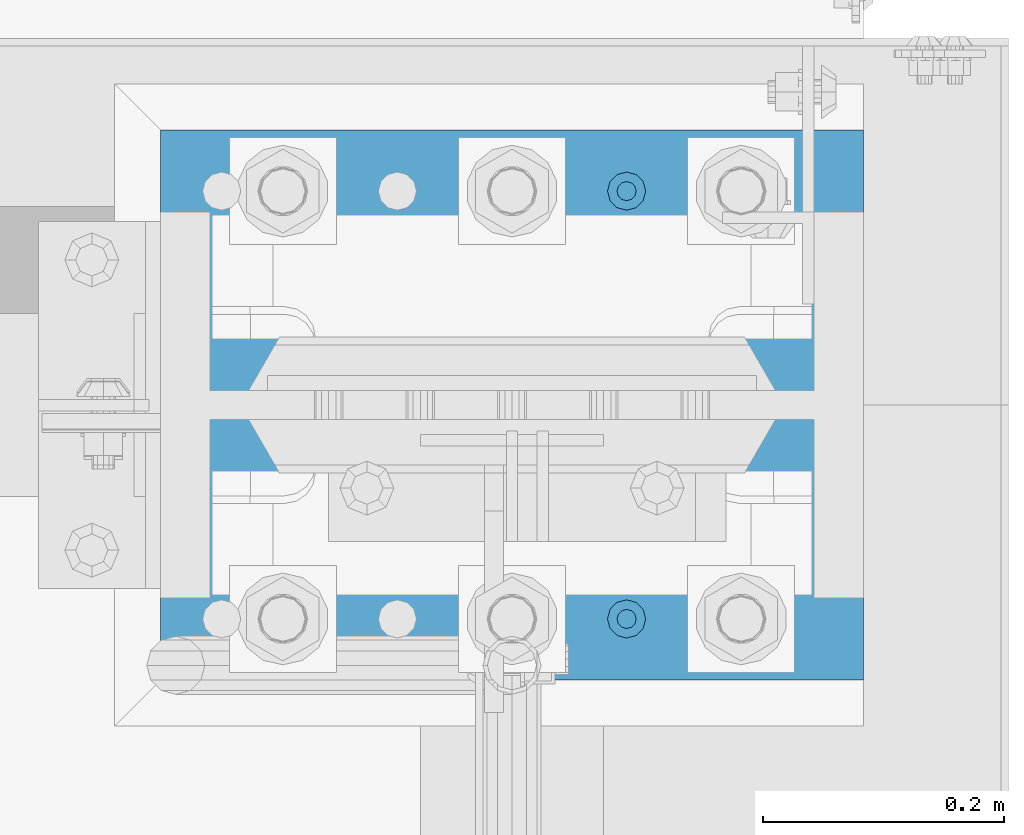
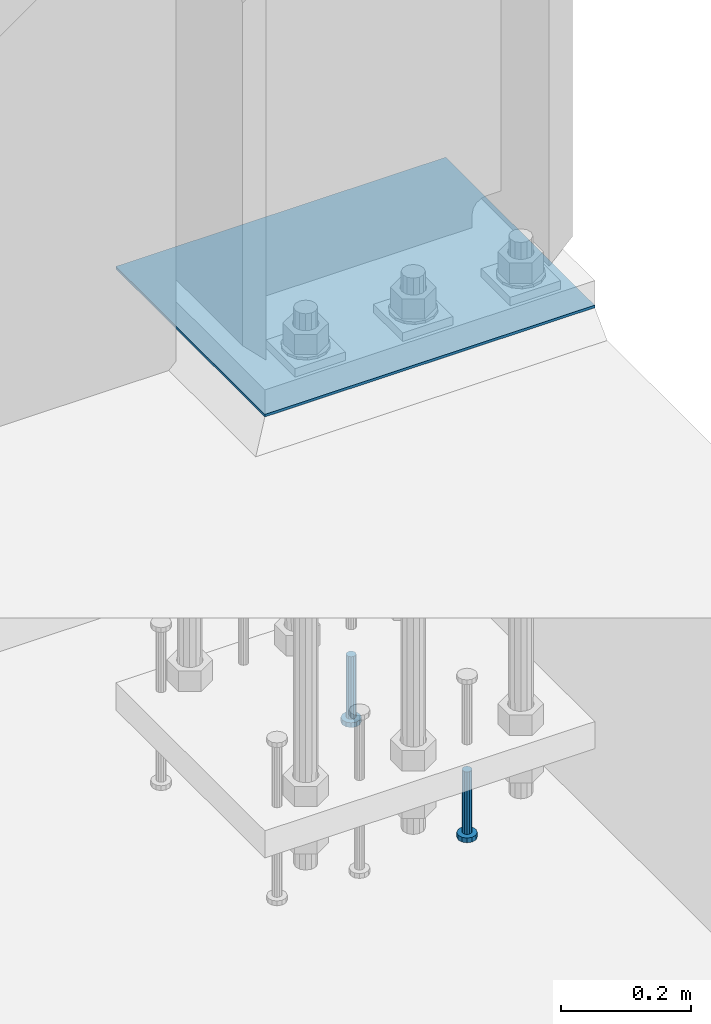
# One storey, part 1355 of 1876: 3 beams, 1 element without a shape of its own.
"""IFC2X3 building model written with IfcOpenShell, lengths in millimetres."""

from ifc_helpers import new_model, si_unit, frame, origin_with_axes, place, context, subcontext, project, spatial, faceted_brep, material, type_object, element, aggregate, save


model = new_model("IFC2X3")

# Units and contexts
model_context = context("Model", 3, precision=1e-05, world=origin_with_axes())
body_context = subcontext(model_context, "Body", "Model", "MODEL_VIEW")
ifc_project = project(units=[si_unit("LENGTHUNIT", "METRE", prefix="MILLI"), si_unit("AREAUNIT", "SQUARE_METRE"), si_unit("VOLUMEUNIT", "CUBIC_METRE"), si_unit("MASSUNIT", "GRAM", prefix="KILO"), si_unit("TIMEUNIT", "SECOND"), si_unit("PLANEANGLEUNIT", "RADIAN"), si_unit("SOLIDANGLEUNIT", "STERADIAN"), si_unit("THERMODYNAMICTEMPERATUREUNIT", "DEGREE_CELSIUS"), si_unit("LUMINOUSINTENSITYUNIT", "LUMEN")], contexts=[model_context])

# Site, building, storey
site_placement = place(None, origin_with_axes())
site = spatial("IfcSite", under=ifc_project, at=site_placement, CompositionType="ELEMENT")
building_placement = place(site_placement, origin_with_axes())
building = spatial("IfcBuilding", under=site, at=building_placement, Name="Undefined", CompositionType="ELEMENT")
storey_placement = place(building_placement, origin_with_axes())
storey = spatial("IfcBuildingStorey", under=building, at=storey_placement, Name="Undefined", CompositionType="ELEMENT", Elevation=0.0)

# Assembly, beams
assembly_placement = place(storey_placement, origin_with_axes())
assembly = element("IfcElementAssembly", 1, at=assembly_placement, inside=storey, Name="TEMPLATE", AssemblyPlace="NOTDEFINED", PredefinedType="RIGID_FRAME")
ifc_material_1 = material(Name="STEEL/A36")
beam_type_1 = type_object("IfcBeamType", PredefinedType="NOTDEFINED")
beam_1_placement = place(assembly_placement, frame((7912.1, 13716.0, 40.4814999999999), z_axis=(0.0, -1.0, 0.0), x_axis=(-1.0, 0.0, 0.0)))
beam_1 = element("IfcBeam", 2, at=beam_1_placement, type_object=beam_type_1, material=ifc_material_1, Name="TEMPLATE", context=body_context, shape_type="Brep", body=[
    faceted_brep([(9.09494701772928e-13, 2.3815, -228.600000000035), (-9.09494701772928e-13, 2.3815, 228.60000000004), (584.200000000001, 2.3815, 228.6), (584.200000000001, 2.3815, -228.6), (-9.09494701772928e-13, -2.3815, 228.60000000004), (584.200000000001, -2.3815, 228.6), (9.09494701772928e-13, -2.3815, -228.600000000035), (584.200000000001, -2.3815, -228.6)], [[[0, 1, 2, 3]], [[1, 4, 5, 2]], [[4, 6, 7, 5]], [[6, 0, 3, 7]], [[5, 7, 3, 2]], [[6, 4, 1, 0]]]),
])
ifc_material_2 = material(Name="STEEL/A108")
beam_type_2 = type_object("IfcBeamType", Name="5/8-DIA_HEADED ANCHOR STUD", PredefinedType="NOTDEFINED")
beam_2_placement = place(assembly_placement, frame((7715.25, 13893.8, -787.4), z_axis=(1.0, 0.0, 0.0), x_axis=(0.0, 0.0, -1.0)))
beam_2 = element("IfcBeam", 3, at=beam_2_placement, type_object=beam_type_2, material=ifc_material_2, Name="HEADED ANCHOR STUD", ObjectType="5/8-DIA_HEADED ANCHOR STUD", context=body_context, shape_type="Brep", body=[
    faceted_brep([(0.0, -7.94000005722046, 0.0), (0.0, -6.86999988555908, -3.97000002861023), (116.84, -6.86999988555908, -3.97000002861023), (116.84, -7.94000005722046, 0.0), (0.0, -3.97000002861023, -6.86999988555908), (116.84, -3.97000002861023, -6.86999988555908), (0.0, 0.0, -7.94000005722046), (116.84, 0.0, -7.94000005722046), (0.0, 3.97000002861023, -6.86999988555908), (116.84, 3.97000002861023, -6.86999988555908), (0.0, 6.86999988555908, -3.97000002861023), (116.84, 6.86999988555908, -3.97000002861023), (0.0, 7.94000005722046, 0.0), (116.84, 7.94000005722046, 0.0), (0.0, 6.86999988555908, 3.97000002861023), (116.84, 6.86999988555908, 3.97000002861023), (0.0, 3.97000002861023, 6.86999988555908), (116.84, 3.97000002861023, 6.86999988555908), (0.0, 0.0, 7.94000005722046), (116.84, 0.0, 7.94000005722046), (0.0, -3.97000002861023, 6.86999988555908), (116.84, -3.97000002861023, 6.86999988555908), (0.0, -6.86999988555908, 3.97000002861023), (116.84, -6.86999988555908, 3.97000002861023), (118.11, -13.75, -7.94000005722046), (118.11, -15.8800001144409, 0.0), (118.11, -7.94000005722046, -13.75), (118.11, 0.0, -15.8800001144409), (118.11, 7.94000005722046, -13.75), (118.11, 13.75, -7.94000005722046), (118.11, 15.8800001144409, 0.0), (118.11, 13.75, 7.94000005722046), (118.11, 7.94000005722046, 13.75), (118.11, 0.0, 15.8800001144409), (118.11, -7.94000005722046, 13.75), (118.11, -13.75, 7.94000005722046), (127.0, -13.75, -7.94000005722046), (127.0, -15.8800001144409, 0.0), (127.0, -7.94000005722046, -13.75), (127.0, 0.0, -15.8800001144409), (127.0, 7.94000005722046, -13.75), (127.0, 13.75, -7.94000005722046), (127.0, 15.8800001144409, 0.0), (127.0, 13.75, 7.94000005722046), (127.0, 7.94000005722046, 13.75), (127.0, 0.0, 15.8800001144409), (127.0, -7.94000005722046, 13.75), (127.0, -13.75, 7.94000005722046)], [[[0, 1, 2, 3]], [[1, 4, 5, 2]], [[4, 6, 7, 5]], [[6, 8, 9, 7]], [[8, 10, 11, 9]], [[10, 12, 13, 11]], [[12, 14, 15, 13]], [[14, 16, 17, 15]], [[16, 18, 19, 17]], [[18, 20, 21, 19]], [[20, 22, 23, 21]], [[22, 0, 3, 23]], [[22, 20, 18, 16, 14, 12, 10, 8, 6, 4, 1, 0]], [[3, 2, 24, 25]], [[2, 5, 26, 24]], [[5, 7, 27, 26]], [[7, 9, 28, 27]], [[9, 11, 29, 28]], [[11, 13, 30, 29]], [[13, 15, 31, 30]], [[15, 17, 32, 31]], [[17, 19, 33, 32]], [[19, 21, 34, 33]], [[21, 23, 35, 34]], [[23, 3, 25, 35]], [[25, 24, 36, 37]], [[24, 26, 38, 36]], [[26, 27, 39, 38]], [[27, 28, 40, 39]], [[28, 29, 41, 40]], [[29, 30, 42, 41]], [[30, 31, 43, 42]], [[31, 32, 44, 43]], [[32, 33, 45, 44]], [[33, 34, 46, 45]], [[34, 35, 47, 46]], [[35, 25, 37, 47]], [[38, 39, 40, 41, 42, 43, 44, 45, 46, 47, 37, 36]]]),
])
beam_3_placement = place(assembly_placement, frame((7715.25, 13538.2, -787.4), z_axis=(1.0, 0.0, 0.0), x_axis=(0.0, 0.0, -1.0)))
beam_3 = element("IfcBeam", 4, at=beam_3_placement, type_object=beam_type_2, material=ifc_material_2, Name="HEADED ANCHOR STUD", ObjectType="5/8-DIA_HEADED ANCHOR STUD", context=body_context, shape_type="Brep", body=[
    faceted_brep([(0.0, -7.94000005722046, 0.0), (0.0, -6.86999988555908, -3.97000002861023), (116.84, -6.86999988555908, -3.97000002861023), (116.84, -7.94000005722046, 0.0), (0.0, -3.97000002861023, -6.86999988555908), (116.84, -3.97000002861023, -6.86999988555908), (0.0, 0.0, -7.94000005722046), (116.84, 0.0, -7.94000005722046), (0.0, 3.97000002861023, -6.86999988555908), (116.84, 3.97000002861023, -6.86999988555908), (0.0, 6.86999988555908, -3.97000002861023), (116.84, 6.86999988555908, -3.97000002861023), (0.0, 7.94000005722046, 0.0), (116.84, 7.94000005722046, 0.0), (0.0, 6.86999988555908, 3.97000002861023), (116.84, 6.86999988555908, 3.97000002861023), (0.0, 3.97000002861023, 6.86999988555908), (116.84, 3.97000002861023, 6.86999988555908), (0.0, 0.0, 7.94000005722046), (116.84, 0.0, 7.94000005722046), (0.0, -3.97000002861023, 6.86999988555908), (116.84, -3.97000002861023, 6.86999988555908), (0.0, -6.86999988555908, 3.97000002861023), (116.84, -6.86999988555908, 3.97000002861023), (118.11, -13.75, -7.94000005722046), (118.11, -15.8800001144409, 0.0), (118.11, -7.94000005722046, -13.75), (118.11, 0.0, -15.8800001144409), (118.11, 7.94000005722046, -13.75), (118.11, 13.75, -7.94000005722046), (118.11, 15.8800001144409, 0.0), (118.11, 13.75, 7.94000005722046), (118.11, 7.94000005722046, 13.75), (118.11, 0.0, 15.8800001144409), (118.11, -7.94000005722046, 13.75), (118.11, -13.75, 7.94000005722046), (127.0, -13.75, -7.94000005722046), (127.0, -15.8800001144409, 0.0), (127.0, -7.94000005722046, -13.75), (127.0, 0.0, -15.8800001144409), (127.0, 7.94000005722046, -13.75), (127.0, 13.75, -7.94000005722046), (127.0, 15.8800001144409, 0.0), (127.0, 13.75, 7.94000005722046), (127.0, 7.94000005722046, 13.75), (127.0, 0.0, 15.8800001144409), (127.0, -7.94000005722046, 13.75), (127.0, -13.75, 7.94000005722046)], [[[0, 1, 2, 3]], [[1, 4, 5, 2]], [[4, 6, 7, 5]], [[6, 8, 9, 7]], [[8, 10, 11, 9]], [[10, 12, 13, 11]], [[12, 14, 15, 13]], [[14, 16, 17, 15]], [[16, 18, 19, 17]], [[18, 20, 21, 19]], [[20, 22, 23, 21]], [[22, 0, 3, 23]], [[22, 20, 18, 16, 14, 12, 10, 8, 6, 4, 1, 0]], [[3, 2, 24, 25]], [[2, 5, 26, 24]], [[5, 7, 27, 26]], [[7, 9, 28, 27]], [[9, 11, 29, 28]], [[11, 13, 30, 29]], [[13, 15, 31, 30]], [[15, 17, 32, 31]], [[17, 19, 33, 32]], [[19, 21, 34, 33]], [[21, 23, 35, 34]], [[23, 3, 25, 35]], [[25, 24, 36, 37]], [[24, 26, 38, 36]], [[26, 27, 39, 38]], [[27, 28, 40, 39]], [[28, 29, 41, 40]], [[29, 30, 42, 41]], [[30, 31, 43, 42]], [[31, 32, 44, 43]], [[32, 33, 45, 44]], [[33, 34, 46, 45]], [[34, 35, 47, 46]], [[35, 25, 37, 47]], [[38, 39, 40, 41, 42, 43, 44, 45, 46, 47, 37, 36]]]),
])
aggregate(assembly, [beam_2, beam_3, beam_1])

save(model, "model.ifc")
